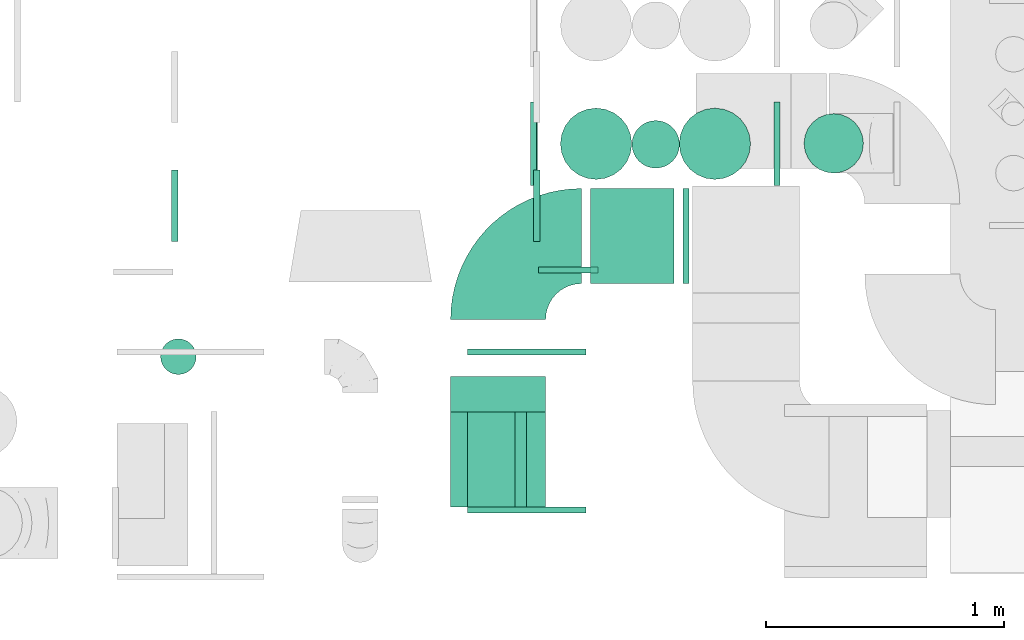
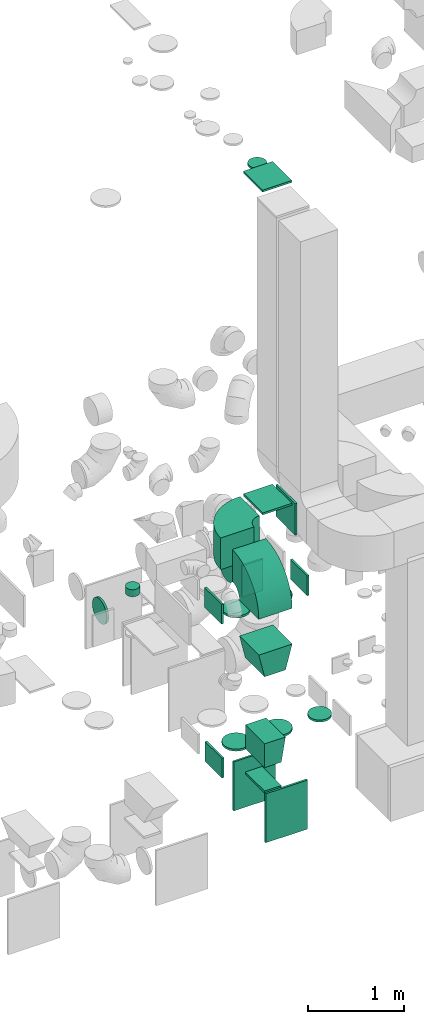
# One storey, part 23 of 59: 23 flow fittings.
"""IFC2X3 building model written with IfcOpenShell, lengths in millimetres."""

from ifc_helpers import new_model, entity, si_unit, converted_unit, derived_unit, direction, frame, frame_2d, origin, origin_2d_with_axis, place, context, subcontext, project, spatial, polyline, circle_curve, parameter, trimmed, segment, composite_curve, rectangle, circle, outline, extrude, faceted_brep, source, transform, mapped, material, type_object, type_shapes, element, save


model = new_model("IFC2X3")

# Units and contexts
model_context = context("Model", 3, precision=0.01, world=origin(), true_north=direction((6.12303176911189e-17, 1.0)))
body_context = subcontext(model_context, "Body", "Model", "MODEL_VIEW")
ifc_project = project(units=[si_unit("LENGTHUNIT", "METRE", prefix="MILLI"), si_unit("AREAUNIT", "SQUARE_METRE"), si_unit("VOLUMEUNIT", "CUBIC_METRE"), converted_unit("PLANEANGLEUNIT", "DEGREE", entity("IfcRatioMeasure", 0.0174532925199433), si_unit("PLANEANGLEUNIT", "RADIAN"), dimensions=[0, 0, 0, 0, 0, 0, 0]), si_unit("MASSUNIT", "GRAM", prefix="KILO"), derived_unit("MASSDENSITYUNIT", [(si_unit("MASSUNIT", "GRAM", prefix="KILO"), 1), (si_unit("LENGTHUNIT", "METRE"), -3)]), derived_unit("MOMENTOFINERTIAUNIT", [(si_unit("LENGTHUNIT", "METRE"), 4)]), si_unit("TIMEUNIT", "SECOND"), si_unit("FREQUENCYUNIT", "HERTZ"), si_unit("THERMODYNAMICTEMPERATUREUNIT", "DEGREE_CELSIUS"), derived_unit("THERMALTRANSMITTANCEUNIT", [(si_unit("MASSUNIT", "GRAM", prefix="KILO"), 1), (si_unit("THERMODYNAMICTEMPERATUREUNIT", "KELVIN"), -1), (si_unit("TIMEUNIT", "SECOND"), -3)]), derived_unit("VOLUMETRICFLOWRATEUNIT", [(si_unit("LENGTHUNIT", "METRE"), 3), (si_unit("TIMEUNIT", "SECOND"), -1)]), derived_unit("MASSFLOWRATEUNIT", [(si_unit("MASSUNIT", "GRAM", prefix="KILO"), 1), (si_unit("TIMEUNIT", "SECOND"), -1)]), derived_unit("ROTATIONALFREQUENCYUNIT", [(si_unit("TIMEUNIT", "SECOND"), -1)]), si_unit("ELECTRICCURRENTUNIT", "AMPERE"), si_unit("ELECTRICVOLTAGEUNIT", "VOLT"), si_unit("POWERUNIT", "WATT"), si_unit("FORCEUNIT", "NEWTON", prefix="KILO"), si_unit("ILLUMINANCEUNIT", "LUX"), si_unit("LUMINOUSFLUXUNIT", "LUMEN"), si_unit("LUMINOUSINTENSITYUNIT", "CANDELA"), derived_unit("USERDEFINED", [(si_unit("MASSUNIT", "GRAM", prefix="KILO"), -1), (si_unit("LENGTHUNIT", "METRE"), -2), (si_unit("TIMEUNIT", "SECOND"), 3), (si_unit("LUMINOUSFLUXUNIT", "LUMEN"), 1)]), derived_unit("LINEARVELOCITYUNIT", [(si_unit("LENGTHUNIT", "METRE"), 1), (si_unit("TIMEUNIT", "SECOND"), -1)]), si_unit("PRESSUREUNIT", "PASCAL"), derived_unit("USERDEFINED", [(si_unit("LENGTHUNIT", "METRE"), -2), (si_unit("MASSUNIT", "GRAM", prefix="KILO"), 1), (si_unit("TIMEUNIT", "SECOND"), -2)]), derived_unit("LINEARFORCEUNIT", [(si_unit("MASSUNIT", "GRAM", prefix="KILO"), 1), (si_unit("LENGTHUNIT", "METRE"), 1), (si_unit("TIMEUNIT", "SECOND"), -2), (si_unit("LENGTHUNIT", "METRE"), -1)]), derived_unit("PLANARFORCEUNIT", [(si_unit("MASSUNIT", "GRAM", prefix="KILO"), 1), (si_unit("LENGTHUNIT", "METRE"), 1), (si_unit("TIMEUNIT", "SECOND"), -2), (si_unit("LENGTHUNIT", "METRE"), -2)])], contexts=[model_context])

# Site, building, storey
site_placement = place(None, origin())
site = spatial("IfcSite", under=ifc_project, at=site_placement, CompositionType="ELEMENT")
building_placement = place(site_placement, origin())
building = spatial("IfcBuilding", under=site, at=building_placement, CompositionType="ELEMENT")
storey_placement = place(building_placement, frame((0.0, 0.0, 28200.0)))
storey = spatial("IfcBuildingStorey", under=building, at=storey_placement, CompositionType="ELEMENT", Elevation=28200.0)

# Flow fittings
ifc_material = material()
duct_fitting_type_1 = type_object("IfcDuctFittingType", PredefinedType="NOTDEFINED", material=ifc_material)
shared_shape_1 = source(origin(), body_context, "Body", "SweptSolid", [
    extrude(circle(Radius=99.9999999999994, at=origin_2d_with_axis()), frame((0.0, 0.0, 0.0), z_axis=(1.0, 0.0, 0.0), x_axis=(0.0, 1.0, 0.0)), (0.0, 0.0, 1.0), 25.0000000000018),
])
type_shapes(duct_fitting_type_1, [shared_shape_1])
flow_fitting_1_placement = place(storey_placement, frame((55631.15, 9734.06, 7677.46), z_axis=(1.0, 0.0, 0.0), x_axis=(0.0, 0.0, 1.0)))
element("IfcFlowFitting", 1, at=flow_fitting_1_placement, inside=storey, type_object=duct_fitting_type_1, material=ifc_material, context=body_context, shape_type="MappedRepresentation", body=[
    mapped(shared_shape_1, transform((0.0, 0.0, 0.0), scale=1.0)),
])
duct_fitting_type_2 = type_object("IfcDuctFittingType", PredefinedType="NOTDEFINED", material=ifc_material)
shared_shape_2 = source(origin(), body_context, "Body", "SweptSolid", [
    extrude(rectangle(XDim=24.9999999999999, YDim=400.0, at=origin_2d_with_axis()), frame((12.5, 0.0, -200.0)), (0.0, 0.0, 1.0), 400.0),
])
type_shapes(duct_fitting_type_2, [shared_shape_2])
flow_fitting_2_placement = place(storey_placement, frame((55745.5, 9348.0, 3500.0)))
element("IfcFlowFitting", 2, at=flow_fitting_2_placement, inside=storey, type_object=duct_fitting_type_2, material=ifc_material, context=body_context, shape_type="MappedRepresentation", body=[
    mapped(shared_shape_2, transform((0.0, 0.0, 0.0), scale=1.0)),
])
duct_fitting_type_3 = type_object("IfcDuctFittingType", PredefinedType="NOTDEFINED", material=ifc_material)
shared_shape_3 = source(origin(), body_context, "Body", "SweptSolid", [
    extrude(rectangle(XDim=24.9999999999999, YDim=350.0, at=origin_2d_with_axis()), frame((12.5, 0.0, -125.0)), (0.0, 0.0, 1.0), 250.0),
])
type_shapes(duct_fitting_type_3, [shared_shape_3])
flow_fitting_3_placement = place(storey_placement, frame((55128.85, 9736.5, 2275.0), z_axis=(0.0, 0.0, 1.0), x_axis=(-1.0, 0.0, 0.0)))
element("IfcFlowFitting", 3, at=flow_fitting_3_placement, inside=storey, type_object=duct_fitting_type_3, material=ifc_material, context=body_context, shape_type="MappedRepresentation", body=[
    mapped(shared_shape_3, transform((0.0, 0.0, 0.0), scale=1.0)),
])
flow_fitting_4_placement = place(storey_placement, frame((56128.85, 9736.5, 2275.0)))
element("IfcFlowFitting", 4, at=flow_fitting_4_placement, inside=storey, type_object=duct_fitting_type_3, material=ifc_material, context=body_context, shape_type="MappedRepresentation", body=[
    mapped(shared_shape_3, transform((0.0, 0.0, 0.0), scale=1.0)),
])
flow_fitting_5_placement = place(storey_placement, frame((55133.85, 9736.5, 325.0), z_axis=(0.0, 0.0, 1.0), x_axis=(-1.0, 0.0, 0.0)))
element("IfcFlowFitting", 5, at=flow_fitting_5_placement, inside=storey, type_object=duct_fitting_type_3, material=ifc_material, context=body_context, shape_type="MappedRepresentation", body=[
    mapped(shared_shape_3, transform((0.0, 0.0, 0.0), scale=1.0)),
])
duct_fitting_type_4 = type_object("IfcDuctFittingType", PredefinedType="NOTDEFINED", material=ifc_material)
shared_shape_4 = source(origin(), body_context, "Body", "SweptSolid", [
    extrude(rectangle(XDim=26.0960000000046, YDim=200.0, at=origin_2d_with_axis()), frame((6.95, 0.0, -200.0)), (0.0, 0.0, 1.0), 400.0),
])
type_shapes(duct_fitting_type_4, [shared_shape_4])
flow_fitting_6_placement = place(storey_placement, frame((54938.0, 8407.5, 932.0), z_axis=(0.0, 1.0, 0.0), x_axis=(0.0, 0.0, 1.0)))
element("IfcFlowFitting", 6, at=flow_fitting_6_placement, inside=storey, type_object=duct_fitting_type_4, material=ifc_material, context=body_context, shape_type="MappedRepresentation", body=[
    mapped(shared_shape_4, transform((0.0, 0.0, 0.0), scale=1.0)),
])
duct_fitting_type_5 = type_object("IfcDuctFittingType", PredefinedType="NOTDEFINED", material=ifc_material)
shared_shape_5 = source(origin(), body_context, "Body", "SweptSolid", [
    extrude(rectangle(XDim=24.9999999999999, YDim=250.0, at=origin_2d_with_axis()), frame((12.5, 0.0, -200.0)), (0.0, 0.0, 1.0), 400.0),
])
type_shapes(duct_fitting_type_5, [shared_shape_5])
flow_fitting_7_placement = place(storey_placement, frame((55262.5, 9218.1, 2900.0), z_axis=(0.0, 0.0, 1.0), x_axis=(0.0, -1.0, 0.0)))
element("IfcFlowFitting", 7, at=flow_fitting_7_placement, inside=storey, type_object=duct_fitting_type_5, material=ifc_material, context=body_context, shape_type="MappedRepresentation", body=[
    mapped(shared_shape_5, transform((0.0, 0.0, 0.0), scale=1.0)),
])
duct_fitting_type_6 = type_object("IfcDuctFittingType", PredefinedType="NOTDEFINED", material=ifc_material)
shared_shape_6 = source(origin(), body_context, "Body", "SweptSolid", [
    extrude(rectangle(XDim=24.9999999999999, YDim=500.0, at=origin_2d_with_axis()), frame((12.5, 0.0, -310.0)), (0.0, 0.0, 1.0), 620.0),
])
type_shapes(duct_fitting_type_6, [shared_shape_6])
for number, where, z_axis, x_axis in (
    (8, (55088.0, 8847.0, 622.0), (0.0, 0.0, 1.0), (0.0, 1.0, 0.0)),
    (9, (55088.0, 8207.5, 622.0), (0.0, 0.0, 1.0), (0.0, -1.0, 0.0)),
):
    element("IfcFlowFitting", number, at=place(storey_placement, frame(where, z_axis=z_axis, x_axis=x_axis)), inside=storey, type_object=duct_fitting_type_6, material=ifc_material, context=body_context, shape_type="MappedRepresentation", body=[
        mapped(shared_shape_6, transform((0.0, 0.0, 0.0), scale=1.0)),
    ])
duct_fitting_type_7 = type_object("IfcDuctFittingType", PredefinedType="NOTDEFINED", material=ifc_material)
shared_shape_7 = source(origin(), body_context, "Body", "SweptSolid", [
    extrude(outline(polyline([(-190.95, -158.25), (117.1, -158.25), (173.91, 85.21), (-100.06, 231.29), (-190.95, -158.25)])), frame((150.0, -2.5, -200.0), z_axis=(0.0, 0.0, 1.0), x_axis=(0.973841173826098, 0.227229769530772, 0.0)), (0.0, 0.0, 1.0), 400.0),
])
type_shapes(duct_fitting_type_7, [shared_shape_7])
flow_fitting_8_placement = place(storey_placement, frame((54968.0, 8407.5, 2697.87), z_axis=(0.0, -1.0, 0.0), x_axis=(0.0, 0.0, -1.0)))
element("IfcFlowFitting", 10, at=flow_fitting_8_placement, inside=storey, type_object=duct_fitting_type_7, material=ifc_material, context=body_context, shape_type="MappedRepresentation", body=[
    mapped(shared_shape_7, transform((0.0, 0.0, 0.0), scale=1.0)),
])
duct_fitting_type_8 = type_object("IfcDuctFittingType", PredefinedType="NOTDEFINED", material=ifc_material)
shared_shape_8 = source(origin(), body_context, "Body", "SweptSolid", [
    extrude(outline(polyline([(-133.57, -110.97), (170.56, -110.97), (129.46, 135.63), (-166.45, 86.31), (-133.57, -110.97)])), frame((150.0, -12.5, -200.0), z_axis=(0.0, 0.0, 1.0), x_axis=(0.986393923832144, -0.164398987305358, 0.0)), (0.0, 0.0, 1.0), 400.0),
])
type_shapes(duct_fitting_type_8, [shared_shape_8])
flow_fitting_9_placement = place(storey_placement, frame((54938.0, 8407.5, 1249.0), z_axis=(0.0, -1.0, 0.0), x_axis=(0.0, 0.0, 1.0)))
element("IfcFlowFitting", 11, at=flow_fitting_9_placement, inside=storey, type_object=duct_fitting_type_8, material=ifc_material, context=body_context, shape_type="MappedRepresentation", body=[
    mapped(shared_shape_8, transform((0.0, 0.0, 0.0), scale=1.0)),
])
duct_fitting_type_9 = type_object("IfcDuctFittingType", PredefinedType="NOTDEFINED", material=ifc_material)
shared_shape_9 = source(origin(), body_context, "Body", "SweptSolid", [
    extrude(rectangle(XDim=400.0, YDim=26.0960121509387, at=origin_2d_with_axis()), frame((6.95, 0.0, -175.0), z_axis=(0.0, 0.0, 1.0), x_axis=(0.0, -1.0, 0.0)), (0.0, 0.0, 1.0), 350.0),
])
type_shapes(duct_fitting_type_9, [shared_shape_9])
flow_fitting_10_placement = place(storey_placement, frame((55532.08, 9348.0, 3700.0), z_axis=(1.0, 0.0, 0.0), x_axis=(0.0, 0.0, 1.0)))
element("IfcFlowFitting", 12, at=flow_fitting_10_placement, inside=storey, type_object=duct_fitting_type_9, material=ifc_material, context=body_context, shape_type="MappedRepresentation", body=[
    mapped(shared_shape_9, transform((0.0, 0.0, 0.0), scale=1.0)),
])
duct_fitting_type_10 = type_object("IfcDuctFittingType", PredefinedType="NOTDEFINED", material=ifc_material)
shared_shape_10 = source(origin(), body_context, "Body", "SweptSolid", [
    extrude(rectangle(XDim=24.9999999999999, YDim=400.0, at=origin_2d_with_axis()), frame((12.5, 0.0, -175.0)), (0.0, 0.0, 1.0), 350.0),
])
type_shapes(duct_fitting_type_10, [shared_shape_10])
flow_fitting_11_placement = place(storey_placement, frame((55532.08, 9348.0, 7780.0), z_axis=(1.0, 0.0, 0.0), x_axis=(0.0, 0.0, 1.0)))
element("IfcFlowFitting", 13, at=flow_fitting_11_placement, inside=storey, type_object=duct_fitting_type_10, material=ifc_material, context=body_context, shape_type="MappedRepresentation", body=[
    mapped(shared_shape_10, transform((0.0, 0.0, 0.0), scale=1.0)),
])
duct_fitting_type_11 = type_object("IfcDuctFittingType", PredefinedType="NOTDEFINED", material=ifc_material)
shared_shape_11 = source(origin(), body_context, "Body", "Brep", [
    faceted_brep([(20.0, 0.0, -125.0), (20.0, 32.35, -120.74), (20.0, 62.5, -108.25), (20.0, 88.39, -88.39), (20.0, 108.25, -62.5), (20.0, 120.74, -32.35), (20.0, 125.0, 0.0), (20.0, 120.74, 32.35), (20.0, 108.25, 62.5), (20.0, 88.39, 88.39), (20.0, 62.5, 108.25), (20.0, 32.35, 120.74), (20.0, 0.0, 125.0), (20.0, -32.35, 120.74), (20.0, -62.5, 108.25), (20.0, -88.39, 88.39), (20.0, -108.25, 62.5), (20.0, -120.74, 32.35), (20.0, -125.0, 0.0), (20.0, -120.74, -32.35), (20.0, -108.25, -62.5), (20.0, -88.39, -88.39), (20.0, -62.5, -108.25), (20.0, -32.35, -120.74), (0.0, 0.0, 125.0), (-6.1, 0.0, 125.0), (-6.1, -32.35, 120.74), (0.0, -32.35, 120.74), (-6.1, -62.5, 108.25), (0.0, -62.5, 108.25), (0.0, -88.39, 88.39), (-6.1, -88.39, 88.39), (0.0, -108.25, 62.5), (-6.1, -108.25, 62.5), (-6.1, -120.74, 32.35), (0.0, -120.74, 32.35), (-6.1, -125.0, 0.0), (0.0, -125.0, 0.0), (-6.1, -120.74, -32.35), (0.0, -120.74, -32.35), (-6.1, -108.25, -62.5), (0.0, -108.25, -62.5), (0.0, -88.39, -88.39), (-6.1, -88.39, -88.39), (0.0, -62.5, -108.25), (-6.1, -62.5, -108.25), (-6.1, -32.35, -120.74), (0.0, -32.35, -120.74), (-6.1, 0.0, -125.0), (0.0, 0.0, -125.0), (-6.1, 32.35, -120.74), (0.0, 32.35, -120.74), (-6.1, 62.5, -108.25), (0.0, 62.5, -108.25), (0.0, 88.39, -88.39), (-6.1, 88.39, -88.39), (0.0, 108.25, -62.5), (-6.1, 108.25, -62.5), (-6.1, 120.74, -32.35), (0.0, 120.74, -32.35), (-6.1, 125.0, 0.0), (0.0, 125.0, 0.0), (-6.1, 120.74, 32.35), (0.0, 120.74, 32.35), (-6.1, 108.25, 62.5), (0.0, 108.25, 62.5), (0.0, 88.39, 88.39), (-6.1, 88.39, 88.39), (0.0, 62.5, 108.25), (-6.1, 62.5, 108.25), (-6.1, 32.35, 120.74), (0.0, 32.35, 120.74)], [[[0, 1, 2, 3, 4, 5, 6, 7, 8, 9, 10, 11, 12, 13, 14, 15, 16, 17, 18, 19, 20, 21, 22, 23]], [[13, 12, 24, 25, 26, 27]], [[14, 13, 27, 26, 28, 29]], [[30, 15, 14, 29, 28, 31]], [[17, 16, 32, 33, 34, 35]], [[18, 17, 35, 34, 36, 37]], [[32, 16, 15, 30, 31, 33]], [[19, 18, 37, 36, 38, 39]], [[20, 19, 39, 38, 40, 41]], [[42, 21, 20, 41, 40, 43]], [[23, 22, 44, 45, 46, 47]], [[0, 23, 47, 46, 48, 49]], [[44, 22, 21, 42, 43, 45]], [[1, 0, 49, 48, 50, 51]], [[2, 1, 51, 50, 52, 53]], [[54, 3, 2, 53, 52, 55]], [[5, 4, 56, 57, 58, 59]], [[6, 5, 59, 58, 60, 61]], [[56, 4, 3, 54, 55, 57]], [[7, 6, 61, 60, 62, 63]], [[8, 7, 63, 62, 64, 65]], [[66, 9, 8, 65, 64, 67]], [[11, 10, 68, 69, 70, 71]], [[12, 11, 71, 70, 25, 24]], [[68, 10, 9, 66, 67, 69]], [[46, 45, 43, 40, 38, 36, 34, 33, 31, 28, 26, 25, 70, 69, 67, 64, 62, 60, 58, 57, 55, 52, 50, 48]]]),
])
type_shapes(duct_fitting_type_11, [shared_shape_11])
flow_fitting_12_placement = place(storey_placement, frame((56380.0, 9738.12, 450.0), z_axis=(-1.0, 0.0, 0.0), x_axis=(0.0, 0.0, 1.0)))
element("IfcFlowFitting", 14, at=flow_fitting_12_placement, inside=storey, type_object=duct_fitting_type_11, material=ifc_material, context=body_context, shape_type="MappedRepresentation", body=[
    mapped(shared_shape_11, transform((0.0, 0.0, 0.0), scale=1.0)),
])
duct_fitting_type_12 = type_object("IfcDuctFittingType", PredefinedType="NOTDEFINED", material=ifc_material)
shared_shape_12 = source(origin(), body_context, "Body", "Brep", [
    faceted_brep([(20.0, 0.0, -150.0), (20.0, 38.82, -144.89), (20.0, 75.0, -129.9), (20.0, 106.07, -106.07), (20.0, 129.9, -75.0), (20.0, 144.89, -38.82), (20.0, 150.0, 0.0), (20.0, 144.89, 38.82), (20.0, 129.9, 75.0), (20.0, 106.07, 106.07), (20.0, 75.0, 129.9), (20.0, 38.82, 144.89), (20.0, 0.0, 150.0), (20.0, -38.82, 144.89), (20.0, -75.0, 129.9), (20.0, -106.07, 106.07), (20.0, -129.9, 75.0), (20.0, -144.89, 38.82), (20.0, -150.0, 0.0), (20.0, -144.89, -38.82), (20.0, -129.9, -75.0), (20.0, -106.07, -106.07), (20.0, -75.0, -129.9), (20.0, -38.82, -144.89), (0.0, 0.0, 150.0), (-6.1, 0.0, 150.0), (-6.1, -38.82, 144.89), (0.0, -38.82, 144.89), (-6.1, -75.0, 129.9), (0.0, -75.0, 129.9), (0.0, -106.07, 106.07), (-6.1, -106.07, 106.07), (0.0, -129.9, 75.0), (-6.1, -129.9, 75.0), (-6.1, -144.89, 38.82), (0.0, -144.89, 38.82), (-6.1, -150.0, 0.0), (0.0, -150.0, 0.0), (-6.1, -144.89, -38.82), (0.0, -144.89, -38.82), (-6.1, -129.9, -75.0), (0.0, -129.9, -75.0), (0.0, -106.07, -106.07), (-6.1, -106.07, -106.07), (0.0, -75.0, -129.9), (-6.1, -75.0, -129.9), (-6.1, -38.82, -144.89), (0.0, -38.82, -144.89), (-6.1, 0.0, -150.0), (0.0, 0.0, -150.0), (-6.1, 38.82, -144.89), (0.0, 38.82, -144.89), (-6.1, 75.0, -129.9), (0.0, 75.0, -129.9), (0.0, 106.07, -106.07), (-6.1, 106.07, -106.07), (0.0, 129.9, -75.0), (-6.1, 129.9, -75.0), (-6.1, 144.89, -38.82), (0.0, 144.89, -38.82), (-6.1, 150.0, 0.0), (0.0, 150.0, 0.0), (-6.1, 144.89, 38.82), (0.0, 144.89, 38.82), (-6.1, 129.9, 75.0), (0.0, 129.9, 75.0), (0.0, 106.07, 106.07), (-6.1, 106.07, 106.07), (0.0, 75.0, 129.9), (-6.1, 75.0, 129.9), (-6.1, 38.82, 144.89), (0.0, 38.82, 144.89)], [[[0, 1, 2, 3, 4, 5, 6, 7, 8, 9, 10, 11, 12, 13, 14, 15, 16, 17, 18, 19, 20, 21, 22, 23]], [[13, 12, 24, 25, 26, 27]], [[14, 13, 27, 26, 28, 29]], [[30, 15, 14, 29, 28, 31]], [[17, 16, 32, 33, 34, 35]], [[18, 17, 35, 34, 36, 37]], [[32, 16, 15, 30, 31, 33]], [[19, 18, 37, 36, 38, 39]], [[20, 19, 39, 38, 40, 41]], [[42, 21, 20, 41, 40, 43]], [[23, 22, 44, 45, 46, 47]], [[0, 23, 47, 46, 48, 49]], [[44, 22, 21, 42, 43, 45]], [[1, 0, 49, 48, 50, 51]], [[2, 1, 51, 50, 52, 53]], [[54, 3, 2, 53, 52, 55]], [[5, 4, 56, 57, 58, 59]], [[6, 5, 59, 58, 60, 61]], [[56, 4, 3, 54, 55, 57]], [[7, 6, 61, 60, 62, 63]], [[8, 7, 63, 62, 64, 65]], [[66, 9, 8, 65, 64, 67]], [[11, 10, 68, 69, 70, 71]], [[12, 11, 71, 70, 25, 24]], [[68, 10, 9, 66, 67, 69]], [[46, 45, 43, 40, 38, 36, 34, 33, 31, 28, 26, 25, 70, 69, 67, 64, 62, 60, 58, 57, 55, 52, 50, 48]]]),
])
type_shapes(duct_fitting_type_12, [shared_shape_12])
for number, where, z_axis, x_axis in (
    (15, (55380.0, 9736.5, 2150.0), (-1.0, 0.0, 0.0), (0.0, 0.0, -1.0)),
    (16, (55380.0, 9736.5, 450.0), (-1.0, 0.0, 0.0), (0.0, 0.0, 1.0)),
    (17, (55880.0, 9736.5, 2150.0), (-1.0, 0.0, 0.0), (0.0, 0.0, -1.0)),
    (18, (55880.0, 9736.5, 450.0), (-1.0, 0.0, 0.0), (0.0, 0.0, 1.0)),
):
    element("IfcFlowFitting", number, at=place(storey_placement, frame(where, z_axis=z_axis, x_axis=x_axis)), inside=storey, type_object=duct_fitting_type_12, material=ifc_material, context=body_context, shape_type="MappedRepresentation", body=[
        mapped(shared_shape_12, transform((0.0, 0.0, 0.0), scale=1.0)),
    ])
duct_fitting_type_13 = type_object("IfcDuctFittingType", PredefinedType="NOTDEFINED", material=ifc_material)
shared_shape_13 = source(origin(), body_context, "Body", "Brep", [
    faceted_brep([(20.0, 38.82, -144.89), (20.0, 75.0, -129.9), (20.0, 106.07, -106.07), (20.0, 129.9, -75.0), (20.0, 144.89, -38.82), (20.0, 150.0, 0.0), (20.0, 144.89, 38.82), (20.0, 129.9, 75.0), (20.0, 106.07, 106.07), (20.0, 75.0, 129.9), (20.0, 38.82, 144.89), (20.0, 0.0, 150.0), (20.0, -38.82, 144.89), (20.0, -75.0, 129.9), (20.0, -106.07, 106.07), (20.0, -129.9, 75.0), (20.0, -144.89, 38.82), (20.0, -150.0, 0.0), (20.0, -144.89, -38.82), (20.0, -129.9, -75.0), (20.0, -106.07, -106.07), (20.0, -75.0, -129.9), (20.0, -38.82, -144.89), (20.0, 0.0, -150.0), (0.0, 0.0, 150.0), (0.0, 38.82, 144.89), (-6.1, 38.82, 144.89), (-6.1, 0.0, 150.0), (0.0, 75.0, 129.9), (-6.1, 75.0, 129.9), (0.0, 106.07, 106.07), (-6.1, 106.07, 106.07), (0.0, 129.9, 75.0), (0.0, 144.89, 38.82), (-6.1, 144.89, 38.82), (-6.1, 129.9, 75.0), (0.0, 150.0, 0.0), (-6.1, 150.0, 0.0), (0.0, 144.89, -38.82), (-6.1, 144.89, -38.82), (0.0, 129.9, -75.0), (-6.1, 129.9, -75.0), (0.0, 106.07, -106.07), (-6.1, 106.07, -106.07), (0.0, 75.0, -129.9), (0.0, 38.82, -144.89), (-6.1, 38.82, -144.89), (-6.1, 75.0, -129.9), (0.0, 0.0, -150.0), (-6.1, 0.0, -150.0), (0.0, -38.82, -144.89), (-6.1, -38.82, -144.89), (0.0, -75.0, -129.9), (-6.1, -75.0, -129.9), (0.0, -106.07, -106.07), (-6.1, -106.07, -106.07), (0.0, -129.9, -75.0), (0.0, -144.89, -38.82), (-6.1, -144.89, -38.82), (-6.1, -129.9, -75.0), (0.0, -150.0, 0.0), (-6.1, -150.0, 0.0), (0.0, -144.89, 38.82), (-6.1, -144.89, 38.82), (0.0, -129.9, 75.0), (-6.1, -129.9, 75.0), (0.0, -106.07, 106.07), (-6.1, -106.07, 106.07), (0.0, -75.0, 129.9), (0.0, -38.82, 144.89), (-6.1, -38.82, 144.89), (-6.1, -75.0, 129.9)], [[[0, 1, 2, 3, 4, 5, 6, 7, 8, 9, 10, 11, 12, 13, 14, 15, 16, 17, 18, 19, 20, 21, 22, 23]], [[24, 11, 10, 25, 26, 27]], [[25, 10, 9, 28, 29, 26]], [[28, 9, 8, 30, 31, 29]], [[32, 7, 6, 33, 34, 35]], [[33, 6, 5, 36, 37, 34]], [[30, 8, 7, 32, 35, 31]], [[36, 5, 4, 38, 39, 37]], [[38, 4, 3, 40, 41, 39]], [[40, 3, 2, 42, 43, 41]], [[44, 1, 0, 45, 46, 47]], [[45, 0, 23, 48, 49, 46]], [[42, 2, 1, 44, 47, 43]], [[48, 23, 22, 50, 51, 49]], [[50, 22, 21, 52, 53, 51]], [[52, 21, 20, 54, 55, 53]], [[56, 19, 18, 57, 58, 59]], [[57, 18, 17, 60, 61, 58]], [[54, 20, 19, 56, 59, 55]], [[60, 17, 16, 62, 63, 61]], [[62, 16, 15, 64, 65, 63]], [[64, 15, 14, 66, 67, 65]], [[68, 13, 12, 69, 70, 71]], [[69, 12, 11, 24, 27, 70]], [[66, 14, 13, 68, 71, 67]], [[49, 51, 53, 55, 59, 58, 61, 63, 65, 67, 71, 70, 27, 26, 29, 31, 35, 34, 37, 39, 41, 43, 47, 46]]]),
])
type_shapes(duct_fitting_type_13, [shared_shape_13])
flow_fitting_13_placement = place(storey_placement, frame((55137.5, 9475.6, 2900.0), z_axis=(0.0, 0.0, -1.0), x_axis=(-1.0, 0.0, 0.0)))
element("IfcFlowFitting", 19, at=flow_fitting_13_placement, inside=storey, type_object=duct_fitting_type_13, material=ifc_material, context=body_context, shape_type="MappedRepresentation", body=[
    mapped(shared_shape_13, transform((0.0, 0.0, 0.0), scale=1.0)),
])
flow_fitting_14_placement = place(storey_placement, frame((53600.03, 9475.6, 2900.0)))
element("IfcFlowFitting", 20, at=flow_fitting_14_placement, inside=storey, type_object=duct_fitting_type_13, material=ifc_material, context=body_context, shape_type="MappedRepresentation", body=[
    mapped(shared_shape_13, transform((0.0, 0.0, 0.0), scale=1.0)),
])
duct_fitting_type_14 = type_object("IfcDuctFittingType", PredefinedType="NOTDEFINED", material=ifc_material)
shared_shape_14 = source(origin(), body_context, "Body", "Brep", [
    faceted_brep([(20.0, 19.41, -72.44), (20.0, 37.5, -64.95), (20.0, 53.03, -53.03), (20.0, 64.95, -37.5), (20.0, 72.44, -19.41), (20.0, 75.0, 0.0), (20.0, 72.44, 19.41), (20.0, 64.95, 37.5), (20.0, 53.03, 53.03), (20.0, 37.5, 64.95), (20.0, 19.41, 72.44), (20.0, 0.0, 75.0), (20.0, -19.41, 72.44), (20.0, -37.5, 64.95), (20.0, -53.03, 53.03), (20.0, -64.95, 37.5), (20.0, -72.44, 19.41), (20.0, -75.0, 0.0), (20.0, -72.44, -19.41), (20.0, -64.95, -37.5), (20.0, -53.03, -53.03), (20.0, -37.5, -64.95), (20.0, -19.41, -72.44), (20.0, 0.0, -75.0), (0.0, 0.0, 75.0), (0.0, 19.41, 72.44), (-68.9, 19.41, 72.44), (-68.9, 0.0, 75.0), (0.0, 37.5, 64.95), (-68.9, 37.5, 64.95), (0.0, 53.03, 53.03), (-68.9, 53.03, 53.03), (0.0, 64.95, 37.5), (0.0, 72.44, 19.41), (-68.9, 72.44, 19.41), (-68.9, 64.95, 37.5), (0.0, 75.0, 0.0), (-68.9, 75.0, 0.0), (0.0, 72.44, -19.41), (-68.9, 72.44, -19.41), (0.0, 64.95, -37.5), (-68.9, 64.95, -37.5), (0.0, 53.03, -53.03), (-68.9, 53.03, -53.03), (0.0, 37.5, -64.95), (0.0, 19.41, -72.44), (-68.9, 19.41, -72.44), (-68.9, 37.5, -64.95), (0.0, 0.0, -75.0), (-68.9, 0.0, -75.0), (0.0, -19.41, -72.44), (-68.9, -19.41, -72.44), (0.0, -37.5, -64.95), (-68.9, -37.5, -64.95), (0.0, -53.03, -53.03), (-68.9, -53.03, -53.03), (0.0, -64.95, -37.5), (0.0, -72.44, -19.41), (-68.9, -72.44, -19.41), (-68.9, -64.95, -37.5), (0.0, -75.0, 0.0), (-68.9, -75.0, 0.0), (0.0, -72.44, 19.41), (-68.9, -72.44, 19.41), (0.0, -64.95, 37.5), (-68.9, -64.95, 37.5), (0.0, -53.03, 53.03), (-68.9, -53.03, 53.03), (0.0, -37.5, 64.95), (0.0, -19.41, 72.44), (-68.9, -19.41, 72.44), (-68.9, -37.5, 64.95)], [[[0, 1, 2, 3, 4, 5, 6, 7, 8, 9, 10, 11, 12, 13, 14, 15, 16, 17, 18, 19, 20, 21, 22, 23]], [[24, 11, 10, 25, 26, 27]], [[25, 10, 9, 28, 29, 26]], [[28, 9, 8, 30, 31, 29]], [[32, 7, 6, 33, 34, 35]], [[33, 6, 5, 36, 37, 34]], [[30, 8, 7, 32, 35, 31]], [[36, 5, 4, 38, 39, 37]], [[38, 4, 3, 40, 41, 39]], [[40, 3, 2, 42, 43, 41]], [[44, 1, 0, 45, 46, 47]], [[48, 49, 46, 45, 0, 23]], [[42, 2, 1, 44, 47, 43]], [[48, 23, 22, 50, 51, 49]], [[50, 22, 21, 52, 53, 51]], [[52, 21, 20, 54, 55, 53]], [[56, 19, 18, 57, 58, 59]], [[57, 18, 17, 60, 61, 58]], [[54, 20, 19, 56, 59, 55]], [[60, 17, 16, 62, 63, 61]], [[62, 16, 15, 64, 65, 63]], [[64, 15, 14, 66, 67, 65]], [[68, 13, 12, 69, 70, 71]], [[69, 12, 11, 24, 27, 70]], [[66, 14, 13, 68, 71, 67]], [[49, 51, 53, 55, 59, 58, 61, 63, 65, 67, 71, 70, 27, 26, 29, 31, 35, 34, 37, 39, 41, 43, 47, 46]]]),
])
type_shapes(duct_fitting_type_14, [shared_shape_14])
flow_fitting_15_placement = place(storey_placement, frame((53622.36, 8840.5, 3525.0), z_axis=(0.0, -1.0, 0.0), x_axis=(0.0, 0.0, -1.0)))
element("IfcFlowFitting", 21, at=flow_fitting_15_placement, inside=storey, type_object=duct_fitting_type_14, material=ifc_material, context=body_context, shape_type="MappedRepresentation", body=[
    mapped(shared_shape_14, transform((0.0, 0.0, 0.0), scale=1.0)),
])
duct_fitting_type_15 = type_object("IfcDuctFittingType", PredefinedType="NOTDEFINED", material=ifc_material)
shared_shape_15 = source(origin(), body_context, "Body", "SweptSolid", [
    extrude(outline(composite_curve([segment(polyline([(-375.0, -175.0), (25.0, -175.0)]), True, "CONTINUOUS"), segment(trimmed(circle_curve(frame_2d((175.0, -175.0), x_axis=(0.0, 1.0)), 150.0), [parameter(0.0)], [parameter(90.0)], True, "PARAMETER"), False, "CONTINUOUS"), segment(polyline([(175.0, -25.0), (175.0, 375.0)]), True, "CONTINUOUS"), segment(trimmed(circle_curve(frame_2d((175.0, -175.0), x_axis=(0.0, 1.0)), 550.0), [parameter(0.0)], [parameter(90.0)], True, "PARAMETER"), True, "CONTINUOUS")], self_intersect=False)), frame((-175.0, 175.0, -200.0), z_axis=(0.0, 0.0, 1.0), x_axis=(-1.0, 0.0, 0.0)), (0.0, 0.0, 1.0), 400.0),
])
type_shapes(duct_fitting_type_15, [shared_shape_15])
for number, where, z_axis, x_axis in (
    (22, (54968.0, 8407.5, 3500.0), (-1.0, 0.0, 0.0), (0.0, 0.0, 1.0)),
    (23, (54968.0, 9348.0, 3500.0), (3.67646958084953e-08, 0.0, 1.0), (-1.0, 0.0, 3.67646958084953e-08)),
):
    element("IfcFlowFitting", number, at=place(storey_placement, frame(where, z_axis=z_axis, x_axis=x_axis)), inside=storey, type_object=duct_fitting_type_15, material=ifc_material, context=body_context, shape_type="MappedRepresentation", body=[
        mapped(shared_shape_15, transform((0.0, 0.0, 0.0), scale=1.0)),
    ])

save(model, "model.ifc")
